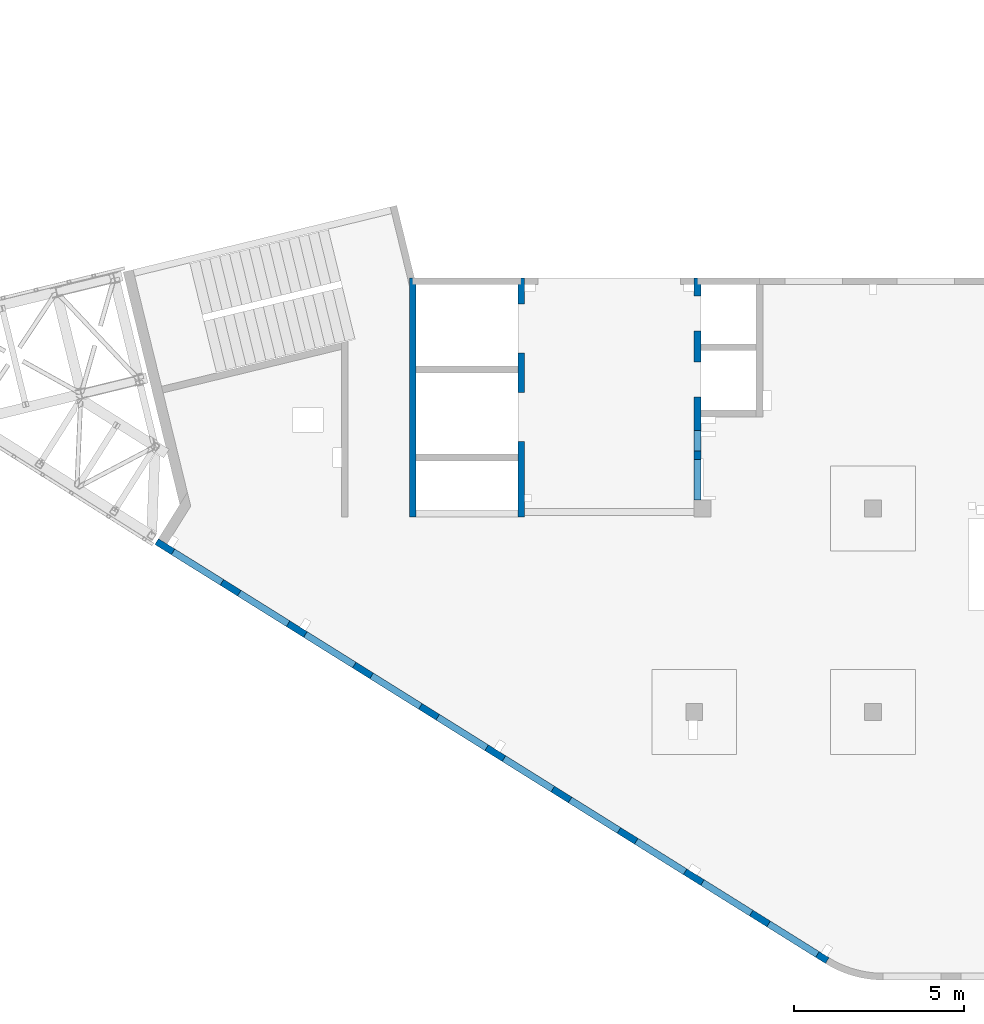
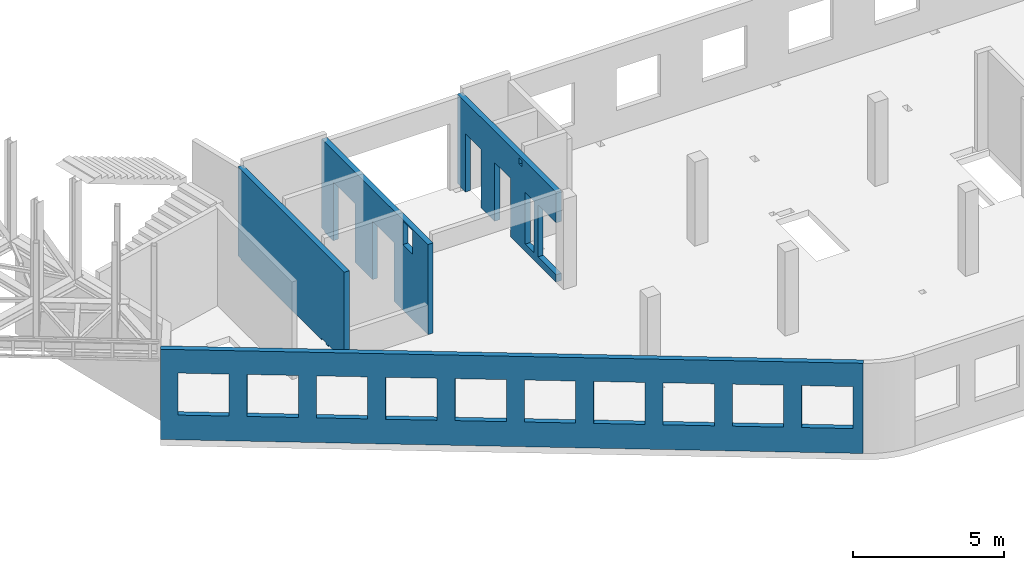
# One storey, part 90 of 92: 4 walls, 20 openings.
"""IFC4 building model written with IfcOpenShell, lengths in millimetres."""

import ifcopenshell
import ifcopenshell.guid

model = None  # the IFC model being written
_history = None  # IfcOwnerHistory: only IFC2X3 demands one
_inside = {}  # id of a spatial element -> (the spatial element, [elements in it])
_under = {}  # id of a project, library or spatial element -> (it, [spatial elements below it])
_declared = {}  # id of a project -> (the project, [libraries it declares])
_typed = {}  # id of a type object -> (the type object, [elements of that type])
_made_of = {}  # id of a material, layer set ... -> (it, [elements and type objects made of it])


def new_model(schema):
    """Start an empty IFC model of exactly this schema.

    Asked for "IFC4X3", IfcOpenShell would pick the latest addendum, in which some entities
    have other attributes; the version numbers below select the first issue.
    IFC2X3 requires an IfcOwnerHistory on every rooted entity: one is made here for all.
    """
    global model, _history
    if schema == "IFC4X3":
        model = ifcopenshell.file(schema_version=(4, 3, 0, 0))
    else:
        model = ifcopenshell.file(schema=schema)
    _inside.clear()
    _under.clear()
    _declared.clear()
    _typed.clear()
    _made_of.clear()
    _history = None
    if model.schema == "IFC2X3":
        org = make("IfcOrganization", Name="unknown")
        user = make(
            "IfcPersonAndOrganization",
            ThePerson=make("IfcPerson", FamilyName="unknown"),
            TheOrganization=org,
        )
        app = make(
            "IfcApplication",
            ApplicationDeveloper=org,
            Version="unknown",
            ApplicationFullName="unknown",
            ApplicationIdentifier="unknown",
        )
        _history = make(
            "IfcOwnerHistory",
            OwningUser=user,
            OwningApplication=app,
            ChangeAction="ADDED",
            CreationDate=0,
        )
    return model


def make(cls, **values):
    """One entity of the class cls with the attributes given. An attribute that is None is left unset."""
    return model.create_entity(
        cls, **{name: value for name, value in values.items() if value is not None}
    )


def entity(cls, *values):
    """Any entity or typed value of the class cls, its attributes in the order of the schema. None: left unset."""
    e = model.create_entity(cls)
    for i, value in enumerate(values):
        if value is not None:
            e[i] = value
    return e


def rooted(cls, **values):
    """An entity with a GlobalId (a new one), such as an element, a storey or a relation."""
    return make(cls, GlobalId=ifcopenshell.guid.new(), OwnerHistory=_history, **values)


def si_unit(unit_type, name, prefix=None):
    """IfcSIUnit, for example si_unit("LENGTHUNIT", "METRE", prefix="MILLI")."""
    return make("IfcSIUnit", UnitType=unit_type, Prefix=prefix, Name=name)


def converted_unit(unit_type, name, factor, base, dimensions=None, offset=None):
    """IfcConversionBasedUnit, such as the inch: factor (a typed value) times the base unit."""
    return make(
        "IfcConversionBasedUnit"
        if offset is None
        else "IfcConversionBasedUnitWithOffset",
        ConversionOffset=offset,
        Dimensions=None
        if dimensions is None
        else entity("IfcDimensionalExponents", *dimensions),
        UnitType=unit_type,
        Name=name,
        ConversionFactor=make(
            "IfcMeasureWithUnit", ValueComponent=factor, UnitComponent=base
        ),
    )


def derived_unit(unit_type, elements):
    """IfcDerivedUnit: a product of units, each with its exponent."""
    return make(
        "IfcDerivedUnit",
        Elements=[
            make("IfcDerivedUnitElement", Unit=unit, Exponent=power)
            for unit, power in elements
        ],
        UnitType=unit_type,
    )


def assignment(units):
    """IfcUnitAssignment: the units of a project."""
    return None if units is None else make("IfcUnitAssignment", Units=units)


def point(xyz):
    """IfcCartesianPoint."""
    return None if xyz is None else make("IfcCartesianPoint", Coordinates=xyz)


def direction(xyz):
    """IfcDirection."""
    return None if xyz is None else make("IfcDirection", DirectionRatios=xyz)


def frame(location, z_axis=None, x_axis=None):
    """IfcAxis2Placement3D, a coordinate frame: its origin and axes. An axis left out is left unset."""
    return make(
        "IfcAxis2Placement3D",
        Location=point(location),
        Axis=direction(z_axis),
        RefDirection=direction(x_axis),
    )


def origin():
    """The frame at (0, 0, 0) with its axes left unset."""
    return frame((0.0, 0.0, 0.0))


def place(relative_to, where):
    """IfcLocalPlacement: puts the frame where relative to a parent placement (None: the world)."""
    return make(
        "IfcLocalPlacement", PlacementRelTo=relative_to, RelativePlacement=where
    )


def context(
    kind, dimensions, precision=None, world=None, true_north=None, identifier=None
):
    """IfcGeometricRepresentationContext, for example the 3D "Model" context."""
    return make(
        "IfcGeometricRepresentationContext",
        ContextIdentifier=identifier,
        ContextType=kind,
        CoordinateSpaceDimension=dimensions,
        Precision=precision,
        WorldCoordinateSystem=world,
        TrueNorth=true_north,
    )


def subcontext(parent, identifier, kind, view, scale=None):
    """IfcGeometricRepresentationSubContext, for example "Body" below "Model"."""
    return make(
        "IfcGeometricRepresentationSubContext",
        ContextIdentifier=identifier,
        ContextType=kind,
        ParentContext=parent,
        TargetScale=scale,
        TargetView=view,
    )


def project(units=None, contexts=None):
    """IfcProject with its units and contexts."""
    return rooted(
        "IfcProject",
        Name="project",
        RepresentationContexts=contexts,
        UnitsInContext=assignment(units),
    )


def spatial(cls, under=None, at=None, **own):
    """A site, building, storey or space (cls), placed at a placement, below another one or the project."""
    s = rooted(cls, ObjectPlacement=at, **own)
    if under is not None:
        _under.setdefault(under.id(), (under, []))[1].append(s)
    return s


def point_list(points):
    """IfcCartesianPointList2D or 3D."""
    cls = (
        "IfcCartesianPointList2D" if len(points[0]) == 2 else "IfcCartesianPointList3D"
    )
    return make(cls, CoordList=points)


def indexed_curve(points, segments=None, self_intersect=None):
    """IfcIndexedPolyCurve: lines and arcs through numbered points (the first is 1)."""
    return make(
        "IfcIndexedPolyCurve",
        Points=point_list(points),
        Segments=segments,
        SelfIntersect=self_intersect,
    )


def outline(outer, holes=None, kind="AREA"):
    """IfcArbitraryClosedProfileDef: a profile drawn as a closed curve; with holes, ...WithVoids."""
    if holes is None:
        return make("IfcArbitraryClosedProfileDef", ProfileType=kind, OuterCurve=outer)
    return make(
        "IfcArbitraryProfileDefWithVoids",
        ProfileType=kind,
        OuterCurve=outer,
        InnerCurves=holes,
    )


def extrude(swept, where, along, depth):
    """IfcExtrudedAreaSolid: the profile swept, set in the frame where, extruded along a direction by depth."""
    return make(
        "IfcExtrudedAreaSolid",
        SweptArea=swept,
        Position=where,
        ExtrudedDirection=direction(along),
        Depth=depth,
    )


def polygons(points, faces, closed=None, point_numbers=None):
    """IfcPolygonalFaceSet: a face is its outer loop, then its inner loops; points numbered from 1."""
    made = []
    for loops in faces:
        if len(loops) == 1:
            made.append(make("IfcIndexedPolygonalFace", CoordIndex=loops[0]))
        else:
            made.append(
                make(
                    "IfcIndexedPolygonalFaceWithVoids",
                    CoordIndex=loops[0],
                    InnerCoordIndices=loops[1:],
                )
            )
    return make(
        "IfcPolygonalFaceSet",
        Coordinates=point_list(points),
        Closed=closed,
        Faces=made,
        PnIndex=point_numbers,
    )


def shape(context_of_items, identifier, shape_type, items):
    """IfcShapeRepresentation: the items that make up one representation, for example the "Body"."""
    return make(
        "IfcShapeRepresentation",
        ContextOfItems=context_of_items,
        RepresentationIdentifier=identifier,
        RepresentationType=shape_type,
        Items=items,
    )


def material(Name=None, Category=None):
    """IfcMaterial."""
    return make("IfcMaterial", Name=Name, Category=Category)


def made_of(thing, what):
    """Note that an element or type object is made of a material, layer set ...; save() writes the relation."""
    if what is not None:
        _made_of.setdefault(what.id(), (what, []))[1].append(thing)
    return thing


def type_object(cls, material=None, **own):
    """A type object (cls), such as IfcWallType, which elements share."""
    return made_of(rooted(cls, **own), material)


def element(
    cls,
    number,
    at=None,
    inside=None,
    cuts=None,
    type_object=None,
    material=None,
    context=None,
    identifier="Body",
    shape_type=None,
    held_by="IfcProductDefinitionShape",
    body=None,
    shapes=None,
    **own,
):
    """One element of the class cls, such as IfcWall. Its Tag is "e" and its number.

    at: its placement. inside: the storey or other place that contains it. cuts: it is an
    opening in that element (IfcRelVoidsElement). A single representation is given by context,
    identifier, shape_type and body (its items); several are given by shapes. held_by: the class
    of the entity that holds the representations. save() writes the other relations.
    """
    e = rooted(cls, Tag="e%d" % number, ObjectPlacement=at, **own)
    if body is not None:
        shapes = [shape(context, identifier, shape_type, body)]
    if shapes is not None:
        e.Representation = make(held_by, Representations=shapes)
    if inside is not None:
        _inside.setdefault(inside.id(), (inside, []))[1].append(e)
    if cuts is not None:
        rooted(
            "IfcRelVoidsElement", RelatingBuildingElement=cuts, RelatedOpeningElement=e
        )
    if type_object is not None:
        _typed.setdefault(type_object.id(), (type_object, []))[1].append(e)
    return made_of(e, material)


def aggregate(whole, parts):
    """IfcRelAggregates: a whole, such as a stair, and the parts it consists of."""
    return rooted("IfcRelAggregates", RelatingObject=whole, RelatedObjects=parts)


def save(model, path):
    """Write the relations noted so far, then the file.

    IfcRelAggregates (storeys below a building ...), IfcRelContainedInSpatialStructure (elements
    in a storey), IfcRelDefinesByType, IfcRelAssociatesMaterial and IfcRelDeclares: one each for
    every whole, place, type object, material and project.
    """
    for whole, parts in _under.values():
        aggregate(whole, parts)
    for where, things in _inside.values():
        rooted(
            "IfcRelContainedInSpatialStructure",
            RelatedElements=things,
            RelatingStructure=where,
        )
    for kind, things in _typed.values():
        rooted("IfcRelDefinesByType", RelatedObjects=things, RelatingType=kind)
    for what, things in _made_of.values():
        rooted("IfcRelAssociatesMaterial", RelatedObjects=things, RelatingMaterial=what)
    for by, libraries in _declared.values():
        rooted("IfcRelDeclares", RelatingContext=by, RelatedDefinitions=libraries)
    model.write(path)


model = new_model("IFC4")

# Units and contexts
model_context = context("Model", 3, precision=0.01, world=origin(), true_north=direction((6.12303176911189e-17, 1.0)))
plan_context = context("Plan", 3, precision=0.01, world=origin(), true_north=direction((6.12303176911189e-17, 1.0)))
body_context = subcontext(model_context, "Body", "Model", "MODEL_VIEW")
ifc_project = project(units=[si_unit("LENGTHUNIT", "METRE", prefix="MILLI"), si_unit("AREAUNIT", "SQUARE_METRE"), si_unit("VOLUMEUNIT", "CUBIC_METRE"), converted_unit("PLANEANGLEUNIT", "DEGREE", entity("IfcRatioMeasure", 0.0174532925199433), si_unit("PLANEANGLEUNIT", "RADIAN"), dimensions=[0, 0, 0, 0, 0, 0, 0]), si_unit("MASSUNIT", "GRAM", prefix="KILO"), derived_unit("MASSDENSITYUNIT", [(si_unit("MASSUNIT", "GRAM", prefix="KILO"), 1), (si_unit("LENGTHUNIT", "METRE"), -3)]), derived_unit("MOMENTOFINERTIAUNIT", [(si_unit("LENGTHUNIT", "METRE"), 4)]), si_unit("TIMEUNIT", "SECOND"), si_unit("FREQUENCYUNIT", "HERTZ"), si_unit("THERMODYNAMICTEMPERATUREUNIT", "DEGREE_CELSIUS"), derived_unit("THERMALTRANSMITTANCEUNIT", [(si_unit("MASSUNIT", "GRAM", prefix="KILO"), 1), (si_unit("THERMODYNAMICTEMPERATUREUNIT", "KELVIN"), -1), (si_unit("TIMEUNIT", "SECOND"), -3)]), derived_unit("VOLUMETRICFLOWRATEUNIT", [(si_unit("LENGTHUNIT", "METRE"), 3), (si_unit("TIMEUNIT", "SECOND"), -1)]), derived_unit("MASSFLOWRATEUNIT", [(si_unit("MASSUNIT", "GRAM", prefix="KILO"), 1), (si_unit("TIMEUNIT", "SECOND"), -1)]), derived_unit("ROTATIONALFREQUENCYUNIT", [(si_unit("TIMEUNIT", "SECOND"), -1)]), si_unit("ELECTRICCURRENTUNIT", "AMPERE"), si_unit("ELECTRICVOLTAGEUNIT", "VOLT"), si_unit("POWERUNIT", "WATT"), si_unit("FORCEUNIT", "NEWTON", prefix="KILO"), si_unit("ILLUMINANCEUNIT", "LUX"), si_unit("LUMINOUSFLUXUNIT", "LUMEN"), si_unit("LUMINOUSINTENSITYUNIT", "CANDELA"), derived_unit("USERDEFINED", [(si_unit("MASSUNIT", "GRAM", prefix="KILO"), -1), (si_unit("LENGTHUNIT", "METRE"), -2), (si_unit("TIMEUNIT", "SECOND"), 3), (si_unit("LUMINOUSFLUXUNIT", "LUMEN"), 1)]), derived_unit("LINEARVELOCITYUNIT", [(si_unit("LENGTHUNIT", "METRE"), 1), (si_unit("TIMEUNIT", "SECOND"), -1)]), si_unit("PRESSUREUNIT", "PASCAL"), derived_unit("USERDEFINED", [(si_unit("LENGTHUNIT", "METRE"), -2), (si_unit("MASSUNIT", "GRAM", prefix="KILO"), 1), (si_unit("TIMEUNIT", "SECOND"), -2)]), derived_unit("LINEARFORCEUNIT", [(si_unit("MASSUNIT", "GRAM", prefix="KILO"), 1), (si_unit("LENGTHUNIT", "METRE"), 1), (si_unit("TIMEUNIT", "SECOND"), -2), (si_unit("LENGTHUNIT", "METRE"), -1)]), derived_unit("PLANARFORCEUNIT", [(si_unit("MASSUNIT", "GRAM", prefix="KILO"), 1), (si_unit("LENGTHUNIT", "METRE"), 1), (si_unit("TIMEUNIT", "SECOND"), -2), (si_unit("LENGTHUNIT", "METRE"), -2)])], contexts=[model_context, plan_context])

# Site, building, storey
site_placement = place(None, origin())
site = spatial("IfcSite", under=ifc_project, at=site_placement, CompositionType="ELEMENT")
building_placement = place(site_placement, origin())
building = spatial("IfcBuilding", under=site, at=building_placement, CompositionType="ELEMENT")
storey_placement = place(building_placement, frame((0.0, 0.0, 15900.0)))
storey = spatial("IfcBuildingStorey", under=building, at=storey_placement, Name="05", CompositionType="ELEMENT", Elevation=15900.0)

# Wall, openings
ifc_material = material()
wall_type = type_object("IfcWallType", Name=":ADSK_ 25_200", PredefinedType="STANDARD")
wall_1_placement = place(storey_placement, frame((19822.35, 371.16, -150.0), z_axis=(0.0, 0.0, 1.0), x_axis=(-0.848052743777574, 0.529911826412025, 0.0)))
wall_1 = element("IfcWall", 1, at=wall_1_placement, inside=storey, type_object=wall_type, material=ifc_material, Name=":ADSK_ 25_200", ObjectType=":ADSK_ 25_200", PredefinedType="NOTDEFINED", context=body_context, shape_type="Tessellation", body=[
    polygons([(-1.48894230278529e-12, -99.9999999999978, -2.16573425859679e-12), (23011.6394501553, -99.9999999999989, 0.0), (23311.6394501553, -99.9999999999989, -2.16573425859679e-12), (23311.6394501553, -99.9999999999989, 2400.0), (23311.6394501553, -99.9999999999989, 3300.0), (23311.6394501553, -99.9999999999989, 3650.0), (23011.6394501553, -99.9999999999989, 3650.0), (-1.48894230278529e-12, -99.9999999999978, 3650.0), (341.63903172165, -99.9999999999988, 2700.0), (2041.63903172165, -99.9999999999981, 2700.0), (2041.63903172165, -99.9999999999981, 1000.00000000001), (341.63903172165, -99.9999999999988, 1000.00000000001), (2641.63903172165, -99.9999999999995, 2700.0), (4341.63903172165, -99.9999999999992, 2700.0), (4341.63903172165, -99.9999999999992, 1000.00000000001), (2641.63903172165, -99.9999999999995, 1000.00000000001), (4941.63903172166, -100.0, 2700.0), (6641.63903172166, -99.9999999999984, 2700.0), (6641.63903172166, -99.9999999999984, 1000.00000000001), (4941.63903172166, -100.0, 1000.00000000001), (7241.63903172167, -99.9999999999984, 2700.0), (8941.63903172167, -100.0, 2700.0), (8941.63903172167, -100.0, 1000.00000000001), (7241.63903172167, -99.9999999999984, 1000.00000000001), (9541.63903172167, -100.0, 2700.0), (11241.6390317217, -99.9999999999989, 2700.0), (11241.6390317217, -99.9999999999989, 1000.00000000001), (9541.63903172167, -100.0, 1000.00000000001), (11841.6390317217, -100.0, 2700.0), (13541.6390317217, -100.0, 2700.0), (13541.6390317217, -100.0, 1000.00000000001), (11841.6390317217, -100.0, 1000.00000000001), (14141.6390317217, -100.0, 2700.0), (15841.6390317217, -100.0, 2700.0), (15841.6390317217, -100.0, 1000.00000000001), (14141.6390317217, -100.0, 1000.00000000001), (16441.6390317217, -99.9999999999989, 2700.0), (18141.6390317217, -99.9999999999989, 2700.0), (18141.6390317217, -99.9999999999989, 1000.00000000001), (16441.6390317217, -99.9999999999989, 1000.00000000001), (18741.6390317217, -100.0, 2700.0), (20441.6390317217, -99.9999999999989, 2700.0), (20441.6390317217, -99.9999999999989, 1000.00000000001), (18741.6390317217, -100.0, 1000.00000000001), (21041.6390317217, -99.9999999999989, 2700.0), (22741.6390317217, -100.000000000001, 2700.0), (22741.6390317217, -100.000000000001, 1000.00000000001), (21041.6390317217, -99.9999999999989, 1000.00000000001), (23311.6394501553, 99.9999999999989, -2.16573425859679e-12), (-2.26725305196851e-12, 100.000000000001, -2.16573425859679e-12), (-2.26725305196851e-12, 100.000000000001, 3650.0), (23311.6394501553, 100.000000000001, 3650.0), (23311.6394501553, 100.000000000001, 3300.0), (23311.6394501553, 100.000000000001, 2400.0), (2041.63903172165, 100.000000000323, 2700.0), (341.63903172165, 100.000000000321, 2700.0), (341.63903172165, 100.000000000321, 1000.00000000001), (2041.63903172165, 100.000000000323, 1000.00000000001), (4341.63903172165, 100.000000000322, 2700.0), (2641.63903172165, 100.00000000032, 2700.0), (2641.63903172165, 100.00000000032, 1000.00000000001), (4341.63903172165, 100.000000000322, 1000.00000000001), (6641.63903172166, 100.000000000322, 2700.0), (4941.63903172166, 100.000000000321, 2700.0), (4941.63903172166, 100.000000000321, 1000.00000000001), (6641.63903172166, 100.000000000322, 1000.00000000001), (8941.63903172166, 100.000000000321, 2700.0), (7241.63903172167, 100.000000000322, 2700.0), (7241.63903172167, 100.000000000322, 1000.00000000001), (8941.63903172166, 100.000000000321, 1000.00000000001), (11241.6390317217, 100.000000000323, 2700.0), (9541.63903172167, 100.000000000321, 2700.0), (9541.63903172167, 100.000000000321, 1000.00000000001), (11241.6390317217, 100.000000000323, 1000.00000000001), (13541.6390317217, 100.000000000319, 2700.0), (11841.6390317217, 100.000000000323, 2700.0), (11841.6390317217, 100.000000000323, 1000.00000000001), (13541.6390317217, 100.000000000319, 1000.00000000001), (15841.6390317217, 100.000000000322, 2700.0), (14141.6390317217, 100.000000000322, 2700.0), (14141.6390317217, 100.000000000322, 1000.00000000001), (15841.6390317217, 100.000000000322, 1000.00000000001), (18141.6390317217, 100.000000000322, 2700.0), (16441.6390317217, 100.000000000322, 2700.0), (16441.6390317217, 100.000000000322, 1000.00000000001), (18141.6390317217, 100.000000000322, 1000.00000000001), (20441.6390317217, 100.000000000322, 2700.0), (18741.6390317217, 100.000000000319, 2700.0), (18741.6390317217, 100.000000000319, 1000.00000000001), (20441.6390317217, 100.000000000322, 1000.00000000001), (22741.6390317217, 100.000000000319, 2700.0), (21041.6390317217, 100.000000000321, 2700.0), (21041.6390317217, 100.000000000323, 1000.00000000001), (22741.6390317217, 100.000000000319, 1000.00000000001)], [[[1, 2, 3, 4, 5, 6, 7, 8], [9, 10, 11, 12], [13, 14, 15, 16], [17, 18, 19, 20], [21, 22, 23, 24], [25, 26, 27, 28], [29, 30, 31, 32], [33, 34, 35, 36], [37, 38, 39, 40], [41, 42, 43, 44], [45, 46, 47, 48]], [[49, 50, 51, 52, 53, 54], [55, 56, 57, 58], [59, 60, 61, 62], [63, 64, 65, 66], [67, 68, 69, 70], [71, 72, 73, 74], [75, 76, 77, 78], [79, 80, 81, 82], [83, 84, 85, 86], [87, 88, 89, 90], [91, 92, 93, 94]], [[3, 2, 1, 50, 49]], [[8, 7, 6, 52, 51]], [[1, 8, 51, 50]], [[3, 49, 54, 53, 52, 6, 5, 4]], [[56, 55, 10, 9]], [[56, 9, 12, 57]], [[57, 12, 11, 58]], [[10, 55, 58, 11]], [[60, 59, 14, 13]], [[60, 13, 16, 61]], [[61, 16, 15, 62]], [[14, 59, 62, 15]], [[64, 63, 18, 17]], [[64, 17, 20, 65]], [[65, 20, 19, 66]], [[18, 63, 66, 19]], [[68, 67, 22, 21]], [[68, 21, 24, 69]], [[69, 24, 23, 70]], [[22, 67, 70, 23]], [[72, 71, 26, 25]], [[72, 25, 28, 73]], [[73, 28, 27, 74]], [[26, 71, 74, 27]], [[76, 75, 30, 29]], [[76, 29, 32, 77]], [[77, 32, 31, 78]], [[30, 75, 78, 31]], [[80, 79, 34, 33]], [[80, 33, 36, 81]], [[81, 36, 35, 82]], [[34, 79, 82, 35]], [[84, 83, 38, 37]], [[84, 37, 40, 85]], [[85, 40, 39, 86]], [[38, 83, 86, 39]], [[88, 87, 42, 41]], [[88, 41, 44, 89]], [[89, 44, 43, 90]], [[42, 87, 90, 43]], [[92, 91, 46, 45]], [[92, 45, 48, 93]], [[93, 48, 47, 94]], [[46, 91, 94, 47]]], closed=True),
])
placement_1 = place(wall_1_placement, frame((16613.72, 10818.86, 150.0), z_axis=(0.0, 0.0, 1.0), x_axis=(-0.848052743777574, -0.529911826412026, 0.0)))
element("IfcOpeningElement", 2, at=placement_1, cuts=wall_1, Name=":ADSK_ 25_200", PredefinedType="OPENING", context=body_context, shape_type="SweptSolid", body=[
    extrude(outline(indexed_curve([(-849.999999999993, -850.0), (849.999999999995, -850.0), (849.999999999995, 850.0), (-849.999999999993, 850.0), (-849.999999999993, -850.0)], self_intersect=False)), frame((1310.08, 12056.6, 1700.0), z_axis=(-0.529911826412026, -0.848052743777574, 0.0), x_axis=(0.0, 0.0, -1.0)), (0.0, 0.0, 1.0), 200.000000000964),
])
element("IfcOpeningElement", 3, at=placement_1, cuts=wall_1, Name=":ADSK_ 25_200", PredefinedType="OPENING", context=body_context, shape_type="SweptSolid", body=[
    extrude(outline(indexed_curve([(-849.999999999993, -850.0), (849.999999999995, -850.0), (849.999999999995, 850.0), (-849.999999999993, 850.0), (-849.999999999993, -850.0)], self_intersect=False)), frame((3260.6, 10837.81, 1700.0), z_axis=(-0.529911826412026, -0.848052743777574, 0.0), x_axis=(0.0, 0.0, -1.0)), (0.0, 0.0, 1.0), 200.000000000964),
])
element("IfcOpeningElement", 4, at=placement_1, cuts=wall_1, Name=":ADSK_ 25_200", PredefinedType="OPENING", context=body_context, shape_type="SweptSolid", body=[
    extrude(outline(indexed_curve([(-849.999999999993, -850.0), (849.999999999995, -850.0), (849.999999999995, 850.0), (-849.999999999993, 850.0), (-849.999999999993, -850.0)], self_intersect=False)), frame((5211.12, 9619.01, 1700.0), z_axis=(-0.529911826412025, -0.848052743777574, 0.0), x_axis=(0.0, 0.0, -1.0)), (0.0, 0.0, 1.0), 200.000000000962),
])
element("IfcOpeningElement", 5, at=placement_1, cuts=wall_1, Name=":ADSK_ 25_200", PredefinedType="OPENING", context=body_context, shape_type="SweptSolid", body=[
    extrude(outline(indexed_curve([(-849.999999999993, -849.999999999999), (849.999999999995, -849.999999999999), (849.999999999995, 850.0), (-849.999999999993, 850.0), (-849.999999999993, -849.999999999999)], self_intersect=False)), frame((7161.64, 8400.21, 1700.0), z_axis=(-0.529911826412026, -0.848052743777574, 0.0), x_axis=(0.0, 0.0, -1.0)), (0.0, 0.0, 1.0), 200.000000000962),
])
element("IfcOpeningElement", 6, at=placement_1, cuts=wall_1, Name=":ADSK_ 25_200", PredefinedType="OPENING", context=body_context, shape_type="SweptSolid", body=[
    extrude(outline(indexed_curve([(-849.999999999993, -849.999999999999), (849.999999999995, -849.999999999999), (849.999999999995, 850.0), (-849.999999999993, 850.0), (-849.999999999993, -849.999999999999)], self_intersect=False)), frame((9112.16, 7181.41, 1700.0), z_axis=(-0.529911826412026, -0.848052743777574, 0.0), x_axis=(0.0, 0.0, -1.0)), (0.0, 0.0, 1.0), 200.000000000962),
])
element("IfcOpeningElement", 7, at=placement_1, cuts=wall_1, Name=":ADSK_ 25_200", PredefinedType="OPENING", context=body_context, shape_type="SweptSolid", body=[
    extrude(outline(indexed_curve([(-849.999999999993, -850.0), (849.999999999995, -850.0), (849.999999999995, 850.0), (-849.999999999993, 850.0), (-849.999999999993, -850.0)], self_intersect=False)), frame((11062.68, 5962.62, 1700.0), z_axis=(-0.529911826412025, -0.848052743777574, 0.0), x_axis=(0.0, 0.0, -1.0)), (0.0, 0.0, 1.0), 200.000000000964),
])
element("IfcOpeningElement", 8, at=placement_1, cuts=wall_1, Name=":ADSK_ 25_200", PredefinedType="OPENING", context=body_context, shape_type="SweptSolid", body=[
    extrude(outline(indexed_curve([(-849.999999999993, -850.0), (849.999999999995, -850.0), (849.999999999995, 850.0), (-849.999999999993, 850.0), (-849.999999999993, -850.0)], self_intersect=False)), frame((13013.21, 4743.82, 1700.0), z_axis=(-0.529911826412025, -0.848052743777574, 0.0), x_axis=(0.0, 0.0, -1.0)), (0.0, 0.0, 1.0), 200.000000000959),
])
element("IfcOpeningElement", 9, at=placement_1, cuts=wall_1, Name=":ADSK_ 25_200", PredefinedType="OPENING", context=body_context, shape_type="SweptSolid", body=[
    extrude(outline(indexed_curve([(-849.999999999993, -850.000000000002), (849.999999999995, -850.000000000002), (849.999999999995, 849.999999999998), (-849.999999999993, 849.999999999998), (-849.999999999993, -850.000000000002)], self_intersect=False)), frame((14963.73, 3525.02, 1700.0), z_axis=(-0.529911826412025, -0.848052743777574, 0.0), x_axis=(0.0, 0.0, -1.0)), (0.0, 0.0, 1.0), 200.000000000962),
])
element("IfcOpeningElement", 10, at=placement_1, cuts=wall_1, Name=":ADSK_ 25_200", PredefinedType="OPENING", context=body_context, shape_type="SweptSolid", body=[
    extrude(outline(indexed_curve([(-849.999999999993, -850.0), (849.999999999995, -850.0), (849.999999999995, 850.0), (-849.999999999993, 850.0), (-849.999999999993, -850.0)], self_intersect=False)), frame((16914.25, 2306.23, 1700.0), z_axis=(-0.529911826412025, -0.848052743777574, 0.0), x_axis=(0.0, 0.0, -1.0)), (0.0, 0.0, 1.0), 200.000000000962),
])
element("IfcOpeningElement", 11, at=placement_1, cuts=wall_1, Name=":ADSK_ 25_200", PredefinedType="OPENING", context=body_context, shape_type="SweptSolid", body=[
    extrude(outline(indexed_curve([(-849.999999999993, -850.0), (849.999999999995, -850.0), (849.999999999995, 850.0), (-849.999999999993, 850.0), (-849.999999999993, -850.0)], self_intersect=False)), frame((18864.77, 1087.43, 1700.0), z_axis=(-0.529911826412025, -0.848052743777574, 0.0), x_axis=(0.0, 0.0, -1.0)), (0.0, 0.0, 1.0), 200.000000000966),
])

wall_2_placement = place(storey_placement, frame((16000.0, 20500.0, -150.0), z_axis=(0.0, 0.0, 1.0), x_axis=(0.0, -1.0, 0.0)))
wall_2 = element("IfcWall", 12, at=wall_2_placement, inside=storey, type_object=wall_type, material=ifc_material, Name=":ADSK_ 25_200", ObjectType=":ADSK_ 25_200", PredefinedType="NOTDEFINED", context=body_context, shape_type="Tessellation", body=[
    polygons([(4100.00063936683, -100.000000000321, 3550.0), (4300.00063936683, -100.00000000032, 3550.0), (4300.00063936683, -100.00000000032, 3300.00000000001), (4100.00063936683, -100.000000000321, 3300.00000000001), (4500.00063936683, -99.9999999999995, 2399.99999999999), (5100.00063936683, -100.000000000001, 2399.99999999999), (5100.00063936683, -100.000000000001, 299.999999999999), (4500.00063936683, -99.9999999999995, 299.999999999999), (6550.00048980714, -99.9999999999982, 3650.0), (399.999999999983, -99.9999999999998, 3650.0), (199.999999999985, -100.0, 3650.0), (0.0, -100.0, 3650.0), (0.0, -100.0, 49.9999999999995), (200.000000000002, -100.0, 49.9999999999995), (200.000000000002, -100.0, -2.16573425859679e-12), (529.999999999996, -99.9999999999995, -2.16573425859679e-12), (529.999999999996, -99.9999999999995, 2369.99999999805), (1570.0, -100.000000000002, 2369.99999999805), (1570.0, -100.000000000002, -2.16573425859679e-12), (2480.0, -100.000000000001, -2.16573425859679e-12), (2480.0, -100.000000000001, 2369.99999999805), (3519.99999999999, -100.000000000001, 2369.99999999805), (3519.99999999999, -100.000000000001, -2.16573425859679e-12), (6550.00048980714, -99.9999999999982, -2.16573425859679e-12), (6550.00048980714, -99.9999999999982, 299.999999999999), (5350.00048980714, -100.0, 299.999999999999), (5350.00048980714, -100.0, 2399.99999999999), (6550.00048980714, -99.9999999999982, 2399.99999999999), (4300.00063936683, 100.0, 3550.0), (4100.00063936683, 99.9999999999999, 3550.0), (4100.00063936683, 99.9999999999999, 3300.00000000001), (4300.00063936683, 100.0, 3300.00000000001), (5100.00063936683, 99.9999999999994, 2399.99999999999), (4500.00063936683, 99.9999999999984, 2399.99999999998), (4500.00063936683, 99.9999999999984, 299.999999999999), (5100.00063936683, 99.9999999999994, 299.999999999999), (0.0, 99.9999999999996, 3650.0), (1950.0, 100.000000000001, 3650.0), (2150.0, 99.9999999999988, 3650.0), (3900.00063936683, 99.9999999999995, 3650.0), (4100.00063936682, 99.9999999999999, 3650.0), (4350.00063936682, 100.0, 3650.0), (4525.00063936682, 100.000000000001, 3650.0), (4675.00063936683, 99.9999999999987, 3650.0), (6450.00063936682, 99.9999999999994, 3650.0), (6530.00063936682, 99.9999999999996, 3650.0), (6550.00048980714, 99.9999999999996, 3650.0), (6550.00048980714, 99.9999999999996, 2399.99999999999), (5350.00048980714, 99.9999999999998, 2399.99999999998), (5350.00048980714, 99.9999999999998, 299.999999999999), (6550.00048980714, 99.9999999999996, 299.999999999999), (6550.00048980714, 99.9999999999996, -2.16573425859679e-12), (4100.00063936683, 99.9999999999999, 0.0), (3900.00063936683, 99.9999999999995, 0.0), (3519.99999999999, 99.9999999999989, -2.16573425859679e-12), (3519.99999999999, 99.9999999999989, 2369.99999999805), (2480.0, 100.000000000002, 2369.99999999804), (2480.0, 100.000000000002, -2.16573425859679e-12), (1570.0, 100.0, -2.16573425859679e-12), (1570.0, 100.0, 2369.99999999805), (529.999999999996, 100.0, 2369.99999999804), (529.999999999996, 100.0, -2.16573425859679e-12), (200.000000000002, 99.9999999999999, -2.16573425859679e-12), (200.000000000002, 99.9999999999999, 49.9999999999995), (0.0, 99.9999999999996, 49.9999999999995), (200.000000000002, 9.88347789881356e-13, 49.9999999999973), (0.0, 6.56688670961758e-13, 49.9999999999973)], [[[9, 10, 11, 12, 13, 14, 15, 16, 17, 18, 19, 20, 21, 22, 23, 24, 25, 26, 27, 28], [1, 2, 3, 4], [5, 6, 7, 8]], [[37, 38, 39, 40, 41, 42, 43, 44, 45, 46, 47, 48, 49, 50, 51, 52, 53, 54, 55, 56, 57, 58, 59, 60, 61, 62, 63, 64, 65], [29, 30, 31, 32], [33, 34, 35, 36]], [[16, 15, 63, 62]], [[24, 52, 51, 25]], [[12, 11, 10, 9, 47, 46, 45, 44, 43, 42, 41, 40, 39, 38, 37]], [[2, 1, 30, 29]], [[2, 29, 32, 3]], [[3, 32, 31, 4]], [[30, 1, 4, 31]], [[33, 6, 5, 34]], [[34, 5, 8, 35]], [[35, 8, 7, 36]], [[6, 33, 36, 7]], [[27, 49, 48, 28]], [[49, 27, 26, 50]], [[50, 26, 25, 51]], [[56, 22, 21, 57]], [[57, 21, 20, 58]], [[22, 56, 55, 23]], [[60, 18, 17, 61]], [[61, 17, 16, 62]], [[18, 60, 59, 19]], [[65, 64, 66, 14, 13, 67]], [[15, 14, 66, 64, 63]], [[13, 12, 37, 65, 67]], [[47, 9, 28, 48]], [[58, 20, 19, 59]], [[52, 24, 23, 55, 54, 53]]], closed=True),
])
placement_2 = place(wall_2_placement, frame((20500.0, -16000.0, 150.0), z_axis=(0.0, 0.0, 1.0), x_axis=(0.0, 1.0, 0.0)))
element("IfcOpeningElement", 13, at=placement_2, cuts=wall_2, Name=":ADSK_ 25_200", PredefinedType="OPENING", context=body_context, shape_type="SweptSolid", body=[
    extrude(outline(indexed_curve([(-1049.99999999999, -600.0), (1049.99999999999, -600.0), (1049.99999999999, 600.0), (-1049.99999999999, 600.0), (-1049.99999999999, -600.0)], self_intersect=False)), frame((15800.0, 14550.0, 1200.0), z_axis=(1.0, 0.0, 0.0), x_axis=(0.0, 0.0, -1.0)), (0.0, 0.0, 1.0), 400.000000001943),
])
element("IfcOpeningElement", 14, at=placement_2, cuts=wall_2, Name=":ADSK_ 25_200", PredefinedType="OPENING", context=body_context, shape_type="SweptSolid", body=[
    extrude(outline(indexed_curve([(-1184.99999999902, -520.000000000001), (1184.99999999902, -520.000000000001), (1184.99999999902, 519.999999999999), (-1184.99999999902, 519.999999999999), (-1184.99999999902, -520.000000000001)], self_intersect=False)), frame((15800.0, 17500.0, 1035.0), z_axis=(1.0, 0.0, 0.0), x_axis=(0.0, 0.0, -1.0)), (0.0, 0.0, 1.0), 400.000000001943),
])
element("IfcOpeningElement", 15, at=placement_2, cuts=wall_2, Name=":ADSK_ 25_200", PredefinedType="OPENING", context=body_context, shape_type="SweptSolid", body=[
    extrude(outline(indexed_curve([(-1184.99999999902, -519.999999999999), (1184.99999999902, -519.999999999999), (1184.99999999902, 520.000000000001), (-1184.99999999902, 520.000000000001), (-1184.99999999902, -519.999999999999)], self_intersect=False)), frame((15800.0, 19450.0, 1035.0), z_axis=(1.0, 0.0, 0.0), x_axis=(0.0, 0.0, -1.0)), (0.0, 0.0, 1.0), 400.000000001943),
])
element("IfcOpeningElement", 16, at=placement_2, cuts=wall_2, Name=":ADSK_ 25_200", PredefinedType="OPENING", context=body_context, shape_type="SweptSolid", body=[
    extrude(outline(indexed_curve([(-100.000000000001, -124.999999999993), (99.9999999999989, -124.999999999993), (99.9999999999989, 124.999999999993), (-100.000000000001, 124.999999999993), (-100.000000000001, -124.999999999993)], self_intersect=False)), frame((15900.0, 16300.0, 3275.0), z_axis=(1.0, 0.0, 0.0), x_axis=(0.0, -1.0, 0.0)), (0.0, 0.0, 1.0), 200.000000000962),
])
element("IfcOpeningElement", 17, at=placement_2, cuts=wall_2, Name=":ADSK_ 25_200", PredefinedType="OPENING", context=body_context, shape_type="SweptSolid", body=[
    extrude(outline(indexed_curve([(-1049.99999999999, -300.000000000001), (1049.99999999999, -300.000000000001), (1049.99999999999, 299.999999999999), (-1049.99999999999, 299.999999999999), (-1049.99999999999, -300.000000000001)], self_intersect=False)), frame((15800.0, 15700.0, 1200.0), z_axis=(1.0, 0.0, 0.0), x_axis=(0.0, 0.0, -1.0)), (0.0, 0.0, 1.0), 400.000000001943),
])

wall_3_placement = place(storey_placement, frame((7600.0, 20500.0, -150.0), z_axis=(0.0, 0.0, 1.0), x_axis=(0.0, -1.0, 0.0)))
wall_3 = element("IfcWall", 18, at=wall_3_placement, inside=storey, type_object=wall_type, material=ifc_material, Name=":ADSK_ 25_200", ObjectType=":ADSK_ 25_200", PredefinedType="NOTDEFINED", context=body_context, shape_type="Tessellation", body=[
    polygons([(7050.00063936678, -99.9999999999996, 3650.0), (226.500105821614, -99.9999999999996, 3650.0), (0.0, -100.000000000001, 3650.0), (0.0, -100.000000000001, 49.9999999999995), (200.000000000002, -100.000000000001, 49.9999999999995), (200.000000000002, -100.000000000001, -2.16573425859679e-12), (226.50010582161, -99.9999999999996, 0.0), (5545.0, -100.000000000001, -2.16573425859679e-12), (5545.0, -100.000000000001, 59.9999999999972), (5855.0, -100.0, 59.9999999999972), (5855.0, -100.0, -2.16573425859679e-12), (5985.0, -100.0, -2.16573425859679e-12), (5985.0, -100.0, 59.9999999999972), (6294.99999999999, -99.9999999999997, 59.9999999999972), (6294.99999999999, -99.9999999999997, -2.16573425859679e-12), (7050.00063936678, -99.9999999999996, -2.16573425859679e-12), (0.0, 100.0, 3650.0), (6850.00063936679, 100.0, 3650.0), (7050.00063936678, 99.9999999999993, 3650.0), (7050.00063936678, 100.0, 1200.0), (7050.00063936678, 99.9999999999993, -2.16573425859679e-12), (6850.0006393668, 100.0, 0.0), (6294.99999999999, 100.0, -2.16573425859679e-12), (6294.99999999999, 100.000000000321, 59.9999999999972), (5985.0, 100.000000000321, 59.9999999999972), (5985.0, 100.000000000001, -2.16573425859679e-12), (5855.0, 100.000000000001, -2.16573425859679e-12), (5855.0, 100.000000000321, 59.9999999999972), (5545.0, 100.000000000321, 59.9999999999972), (5545.0, 100.0, -2.16573425859679e-12), (200.000000000002, 100.0, -2.16573425859679e-12), (200.000000000002, 100.0, 49.9999999999995), (0.0, 100.0, 49.9999999999995), (200.000000000002, -6.87656940234796e-13, 0.0), (0.0, 50.6443876577722, 3650.0)], [[[1, 2, 3, 4, 5, 6, 7, 8, 9, 10, 11, 12, 13, 14, 15, 16]], [[17, 18, 19, 20, 21, 22, 23, 24, 25, 26, 27, 28, 29, 30, 31, 32, 33]], [[6, 34, 31, 30, 8, 7]], [[3, 2, 1, 19, 18, 17, 35]], [[6, 5, 32, 31, 34]], [[4, 3, 35, 17, 33]], [[13, 25, 24, 14]], [[25, 13, 12, 26]], [[14, 24, 23, 15]], [[9, 29, 28, 10]], [[29, 9, 8, 30]], [[10, 28, 27, 11]], [[1, 16, 21, 20, 19]], [[33, 32, 5, 4]], [[16, 15, 23, 22, 21]], [[26, 12, 11, 27]]], closed=True),
])
placement_3 = place(wall_3_placement, origin())
element("IfcOpeningElement", 19, at=placement_3, cuts=wall_3, Name=":ADSK_ 25_200", PredefinedType="OPENING", context=body_context, shape_type="SweptSolid", body=[
    extrude(outline(indexed_curve([(-154.999999999995, -154.999999999999), (154.999999999991, -154.999999999999), (154.999999999991, 154.999999999999), (-154.999999999995, 154.999999999999), (-154.999999999995, -154.999999999999)], self_intersect=False)), frame((6140.0, -100.0, -95.0), z_axis=(0.0, 1.0, 0.0), x_axis=(0.0, 0.0, -1.0)), (0.0, 0.0, 1.0), 200.000000000962),
])
element("IfcOpeningElement", 20, at=placement_3, cuts=wall_3, Name=":ADSK_ 25_200", PredefinedType="OPENING", context=body_context, shape_type="SweptSolid", body=[
    extrude(outline(indexed_curve([(-154.999999999995, -154.999999999999), (154.999999999991, -154.999999999999), (154.999999999991, 154.999999999999), (-154.999999999995, 154.999999999999), (-154.999999999995, -154.999999999999)], self_intersect=False)), frame((5700.0, -100.0, -95.0), z_axis=(0.0, 1.0, 0.0), x_axis=(0.0, 0.0, -1.0)), (0.0, 0.0, 1.0), 200.000000000962),
])

wall_4_placement = place(storey_placement, frame((10800.0, 20500.0, -150.0), z_axis=(0.0, 0.0, 1.0), x_axis=(0.0, -1.0, 0.0)))
wall_4 = element("IfcWall", 21, at=wall_4_placement, inside=storey, type_object=wall_type, material=ifc_material, Name=":ADSK_ 25_200", ObjectType=":ADSK_ 25_200", PredefinedType="NOTDEFINED", context=body_context, shape_type="Tessellation", body=[
    polygons([(5400.00000000002, -99.999999999999, 3600.0), (6050.00000000002, -99.9999999999979, 3600.0), (6050.00000000002, -99.9999999999979, 2650.00000000002), (5400.00000000002, -99.999999999999, 2650.00000000002), (7050.00063936681, -99.9999999999985, 3650.0), (6850.00063936682, -99.9999999999988, 3650.0), (200.000000000028, -99.9999999999985, 3650.0), (0.0, -99.9999999999988, 3650.0), (0.0, -99.9999999999988, 49.9999999999995), (200.000000000028, -99.9999999999985, 49.9999999999995), (200.000000000028, -99.9999999999985, -2.16573425859679e-12), (780.000000000018, -99.9999999999976, -2.16573425859679e-12), (780.000000000018, -99.9999999999976, 2369.99999999805), (2220.00000000001, -99.9999999999975, 2369.99999999804), (2220.00000000001, -99.9999999999975, -2.16573425859679e-12), (3380.00000000002, -99.9999999999978, -2.16573425859679e-12), (3380.00000000002, -99.9999999999978, 2369.99999999805), (4820.00000000001, -99.9999999999977, 2369.99999999805), (4820.00000000001, -99.9999999999977, -2.16573425859679e-12), (6850.00063936681, -99.9999999999988, 0.0), (7050.00063936681, -99.9999999999985, -2.16573425859679e-12), (7050.00063936681, -99.9999999999985, 1200.0), (0.0, 100.000000000001, 3650.0), (200.000000000002, 100.000000000001, 3650.0), (399.999999999983, 100.000000000002, 3650.0), (6400.00063936681, 100.0, 3650.0), (6600.00063936681, 100.000000000001, 3650.0), (7050.00063936681, 100.000000000001, 3650.0), (7050.00063936681, 100.000000000001, -2.16573425859679e-12), (6600.00063936682, 100.000000000001, 0.0), (6400.00063936682, 100.0, 0.0), (4820.00000000001, 100.000000000002, -2.16573425859679e-12), (4820.00000000002, 100.000000000002, 2369.99999999805), (3380.00000000002, 100.000000000002, 2369.99999999804), (3380.00000000002, 100.000000000002, -2.16573425859679e-12), (2220.00000000001, 100.000000000003, -2.16573425859679e-12), (2220.00000000001, 100.000000000003, 2369.99999999805), (780.000000000018, 100.000000000002, 2369.99999999805), (780.000000000018, 100.000000000002, -2.16573425859679e-12), (400.00000000003, 100.000000000002, 0.0), (200.000000000028, 100.000000000001, -2.16573425859679e-12), (200.000000000028, 100.000000000001, 49.9999999999995), (0.0, 100.000000000001, 49.9999999999995), (6050.00000000002, 100.000000000323, 3600.0), (5400.00000000002, 100.000000000322, 3600.0), (5400.00000000002, 100.000000000322, 2650.00000000002), (6050.00000000002, 100.000000000323, 2650.00000000002), (0.0, -2.0866896252195e-12, 3650.0), (200.000000000028, 3.95210189063612e-13, 49.9999999999973), (0.0, 7.90446333772861e-14, 49.9999999999973)], [[[5, 6, 7, 8, 9, 10, 11, 12, 13, 14, 15, 16, 17, 18, 19, 20, 21, 22], [1, 2, 3, 4]], [[23, 24, 25, 26, 27, 28, 29, 30, 31, 32, 33, 34, 35, 36, 37, 38, 39, 40, 41, 42, 43], [44, 45, 46, 47]], [[12, 11, 41, 40, 39]], [[8, 7, 6, 5, 28, 27, 26, 25, 24, 23, 48]], [[45, 44, 2, 1]], [[45, 1, 4, 46]], [[46, 4, 3, 47]], [[2, 44, 47, 3]], [[13, 38, 37, 14]], [[14, 37, 36, 15]], [[38, 13, 12, 39]], [[33, 18, 17, 34]], [[34, 17, 16, 35]], [[18, 33, 32, 19]], [[43, 42, 49, 10, 9, 50]], [[11, 10, 49, 42, 41]], [[43, 50, 9, 8, 48, 23]], [[5, 22, 21, 29, 28]], [[15, 36, 35, 16]], [[29, 21, 20, 19, 32, 31, 30]]], closed=True),
])
placement_4 = place(wall_4_placement, frame((20500.0, -10800.0, 150.0), z_axis=(0.0, 0.0, 1.0), x_axis=(0.0, 1.0, 0.0)))
element("IfcOpeningElement", 22, at=placement_4, cuts=wall_4, Name=":ADSK_ 25_200", PredefinedType="OPENING", context=body_context, shape_type="SweptSolid", body=[
    extrude(outline(indexed_curve([(-719.999999999999, -1184.99999999902), (719.999999999999, -1184.99999999902), (719.999999999999, 1184.99999999902), (-719.999999999999, 1184.99999999902), (-719.999999999999, -1184.99999999902)], self_intersect=False)), frame((10600.0, 19000.0, 1035.0), z_axis=(1.0, 0.0, 0.0), x_axis=(0.0, -1.0, 0.0)), (0.0, 0.0, 1.0), 400.000000001943),
])
element("IfcOpeningElement", 23, at=placement_4, cuts=wall_4, Name=":ADSK_ 25_200", PredefinedType="OPENING", context=body_context, shape_type="SweptSolid", body=[
    extrude(outline(indexed_curve([(-1184.99999999902, -719.999999999999), (1184.99999999902, -719.999999999999), (1184.99999999902, 720.000000000001), (-1184.99999999902, 720.000000000001), (-1184.99999999902, -719.999999999999)], self_intersect=False)), frame((10600.0, 16400.0, 1035.0), z_axis=(1.0, 0.0, 0.0), x_axis=(0.0, 0.0, -1.0)), (0.0, 0.0, 1.0), 400.000000001943),
])
element("IfcOpeningElement", 24, at=placement_4, cuts=wall_4, Name=":ADSK_ 25_200", PredefinedType="OPENING", context=body_context, shape_type="SweptSolid", body=[
    extrude(outline(indexed_curve([(-474.999999999994, -325.0), (474.999999999992, -325.0), (474.999999999992, 325.0), (-474.999999999994, 325.0), (-474.999999999994, -325.0)], self_intersect=False)), frame((10700.0, 14775.0, 2975.0), z_axis=(1.0, 0.0, 0.0), x_axis=(0.0, 0.0, -1.0)), (0.0, 0.0, 1.0), 200.000000000962),
])

save(model, "model.ifc")
